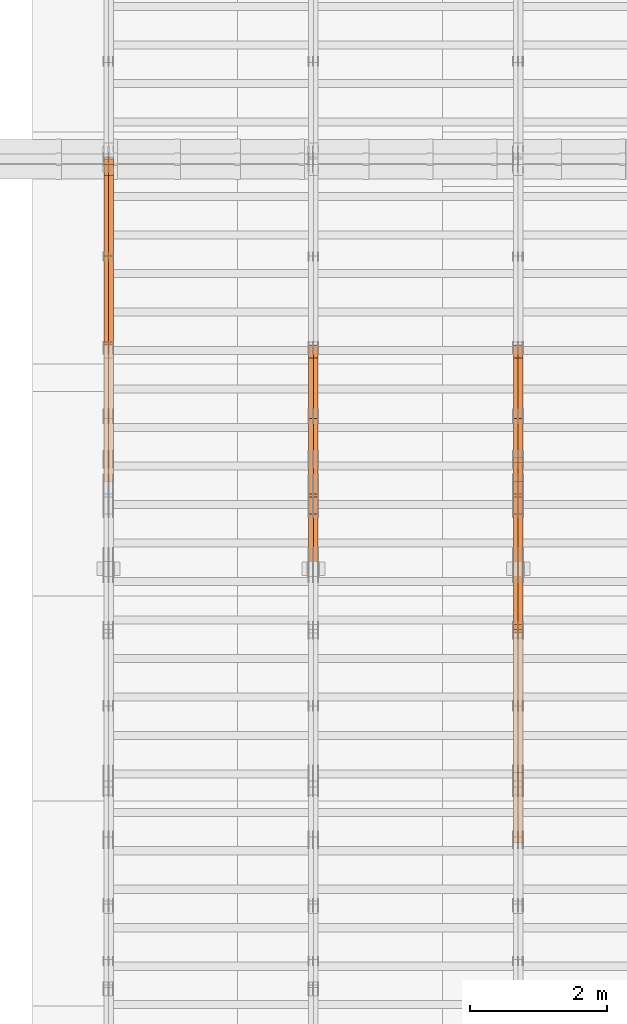
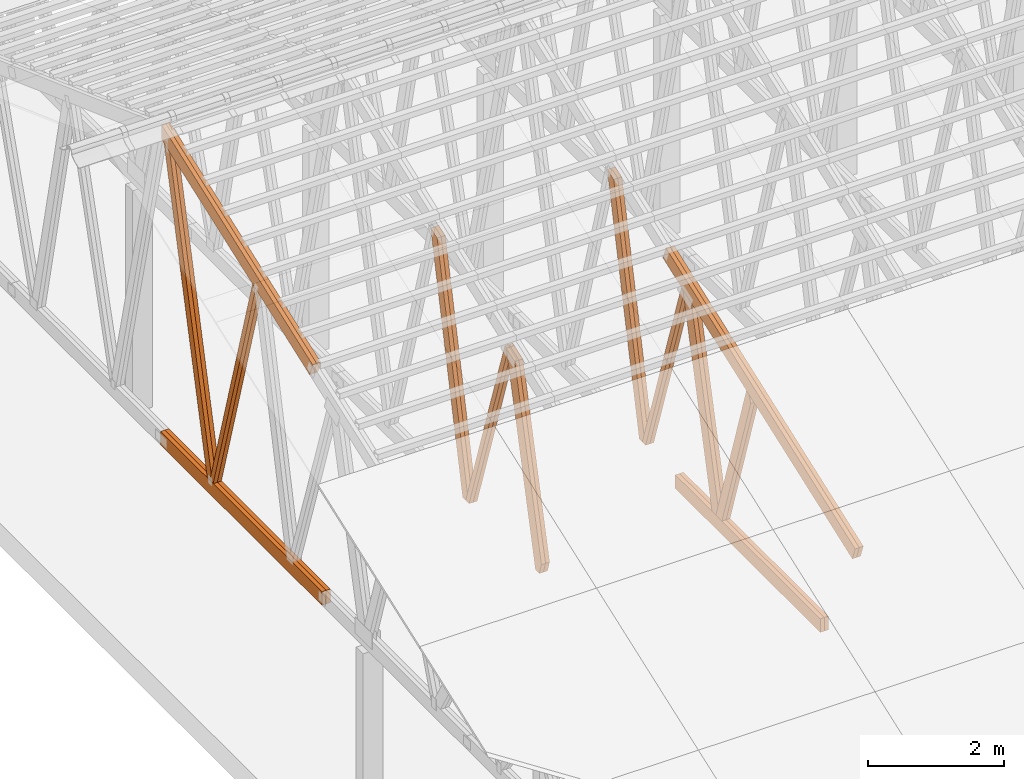
# One storey, part 16 of 189: 26 proxies.
"""IFC2X3 building model written with IfcOpenShell, lengths in millimetres."""

from ifc_helpers import new_model, entity, si_unit, converted_unit, derived_unit, direction, frame, origin, origin_2d_with_axis, place, context, subcontext, project, spatial, polyline, rectangle, outline, extrude, source, transform, mapped, material, type_object, type_shapes, element, save


model = new_model("IFC2X3")

# Units and contexts
model_context = context("Model", 3, precision=0.01, world=origin(), true_north=direction((6.12303176911189e-17, 1.0)))
body_context = subcontext(model_context, "Body", "Model", "MODEL_VIEW")
ifc_project = project(units=[si_unit("LENGTHUNIT", "METRE", prefix="MILLI"), si_unit("AREAUNIT", "SQUARE_METRE"), si_unit("VOLUMEUNIT", "CUBIC_METRE"), converted_unit("PLANEANGLEUNIT", "DEGREE", entity("IfcRatioMeasure", 0.0174532925199433), si_unit("PLANEANGLEUNIT", "RADIAN"), dimensions=[0, 0, 0, 0, 0, 0, 0]), si_unit("MASSUNIT", "GRAM", prefix="KILO"), derived_unit("MASSDENSITYUNIT", [(si_unit("MASSUNIT", "GRAM", prefix="KILO"), 1), (si_unit("LENGTHUNIT", "METRE"), -3)]), si_unit("TIMEUNIT", "SECOND"), si_unit("FREQUENCYUNIT", "HERTZ"), si_unit("THERMODYNAMICTEMPERATUREUNIT", "DEGREE_CELSIUS"), derived_unit("THERMALTRANSMITTANCEUNIT", [(si_unit("MASSUNIT", "GRAM", prefix="KILO"), 1), (si_unit("THERMODYNAMICTEMPERATUREUNIT", "KELVIN"), -1), (si_unit("TIMEUNIT", "SECOND"), -3)]), derived_unit("VOLUMETRICFLOWRATEUNIT", [(si_unit("LENGTHUNIT", "METRE"), 3), (si_unit("TIMEUNIT", "SECOND"), -1)]), si_unit("ELECTRICCURRENTUNIT", "AMPERE"), si_unit("ELECTRICVOLTAGEUNIT", "VOLT"), si_unit("POWERUNIT", "WATT"), si_unit("FORCEUNIT", "NEWTON"), si_unit("ILLUMINANCEUNIT", "LUX"), si_unit("LUMINOUSFLUXUNIT", "LUMEN"), si_unit("LUMINOUSINTENSITYUNIT", "CANDELA"), derived_unit("USERDEFINED", [(si_unit("MASSUNIT", "GRAM", prefix="KILO"), -1), (si_unit("LENGTHUNIT", "METRE"), -2), (si_unit("TIMEUNIT", "SECOND"), 3), (si_unit("LUMINOUSFLUXUNIT", "LUMEN"), 1)]), derived_unit("LINEARVELOCITYUNIT", [(si_unit("LENGTHUNIT", "METRE"), 1), (si_unit("TIMEUNIT", "SECOND"), -1)]), si_unit("PRESSUREUNIT", "PASCAL"), derived_unit("USERDEFINED", [(si_unit("LENGTHUNIT", "METRE"), -2), (si_unit("MASSUNIT", "GRAM", prefix="KILO"), 1), (si_unit("TIMEUNIT", "SECOND"), -2)])], contexts=[model_context])

# Site, building, storey
site_placement = place(None, origin())
site = spatial("IfcSite", under=ifc_project, at=site_placement, CompositionType="ELEMENT")
building_placement = place(site_placement, origin())
building = spatial("IfcBuilding", under=site, at=building_placement, CompositionType="ELEMENT")
storey_placement = place(building_placement, origin())
storey = spatial("IfcBuildingStorey", under=building, at=storey_placement, Name="Default", CompositionType="ELEMENT", Elevation=0.0)

# Proxies
ifc_material_1 = material(Name="IfcSurfaceStyle #36526")
building_element_proxy_type_1 = type_object("IfcBuildingElementProxyType", Name="T1-W3 36524", PredefinedType="NOTDEFINED", material=ifc_material_1)
shared_shape_1 = source(origin(), body_context, "Body", "SweptSolid", [
    extrude(outline(polyline([(-2625.55080717397, -84.9998286237256), (1749.48871563991, -84.9998286237256), (1768.20584427244, 0.000602085469291858), (1625.445846867, 85.0000405971208), (-2517.58959960538, 84.9990145648612), (-2625.55080717397, -84.9998286237256)])), frame((1768.20584427244, 85.0000405971208, 0.0), z_axis=(0.0, 0.0, 1.0), x_axis=(-1.0, 0.0, 0.0)), (0.0, 0.0, 1.0), 69.9999999999997),
])
type_shapes(building_element_proxy_type_1, [shared_shape_1])
proxy_1_placement = place(building_placement, frame((6335.0, 10918.6728403286, 263.278932236374), z_axis=(-1.0, 0.0, 0.0), x_axis=(0.0, 0.215047682154604, 0.976603550269982)))
element("IfcBuildingElementProxy", 1, at=proxy_1_placement, inside=storey, type_object=building_element_proxy_type_1, material=ifc_material_1, Name="T1-W3", context=body_context, shape_type="MappedRepresentation", body=[
    mapped(shared_shape_1, transform((0.0, 0.0, 0.0), scale=1.0)),
])
ifc_material_2 = material(Name="IfcSurfaceStyle #36460")
building_element_proxy_type_2 = type_object("IfcBuildingElementProxyType", Name="T1-W3 36458", PredefinedType="NOTDEFINED", material=ifc_material_2)
shared_shape_2 = source(origin(), body_context, "Body", "SweptSolid", [
    extrude(outline(polyline([(-2625.55080717397, -84.9998286237256), (1749.48871563991, -84.9998286237256), (1768.20584427244, 0.000602085469291858), (1625.445846867, 85.0000405971208), (-2517.58959960538, 84.9990145648612), (-2625.55080717397, -84.9998286237256)])), frame((1768.20584427244, 85.0000405971208, 0.0), z_axis=(0.0, 0.0, 1.0), x_axis=(-1.0, 0.0, 0.0)), (0.0, 0.0, 1.0), 69.9999999999997),
])
type_shapes(building_element_proxy_type_2, [shared_shape_2])
proxy_2_placement = place(building_placement, frame((6265.0, 10918.6728403286, 263.278932236374), z_axis=(-1.0, 0.0, 0.0), x_axis=(0.0, 0.215047682154604, 0.976603550269982)))
element("IfcBuildingElementProxy", 2, at=proxy_2_placement, inside=storey, type_object=building_element_proxy_type_2, material=ifc_material_2, Name="T1-W3", context=body_context, shape_type="MappedRepresentation", body=[
    mapped(shared_shape_2, transform((0.0, 0.0, 0.0), scale=1.0)),
])
ifc_material_3 = material(Name="IfcSurfaceStyle #36262")
building_element_proxy_type_3 = type_object("IfcBuildingElementProxyType", Name="T1-W7 36260", PredefinedType="NOTDEFINED", material=ifc_material_3)
shared_shape_3 = source(origin(), body_context, "Body", "SweptSolid", [
    extrude(outline(polyline([(-2158.15323194511, -47.5001976605119), (1398.58481981178, -47.5001976605119), (1473.93376219819, -0.000131511554346808), (1475.30069254941, 47.5002634162891), (-2189.66604261427, 47.5002634162891), (-2158.15323194511, -47.5001976605119)])), frame((1475.30069254941, 47.5002634162891, 0.0), z_axis=(0.0, 0.0, 1.0), x_axis=(-1.0, 0.0, 0.0)), (0.0, 0.0, 1.0), 69.9999999999998),
])
type_shapes(building_element_proxy_type_3, [shared_shape_3])
proxy_3_placement = place(building_placement, frame((6335.0, 9847.787109375, 3723.57788085937), z_axis=(-1.0, 0.0, 0.0), x_axis=(0.0, 0.314845237923105, -0.949143021971475)))
element("IfcBuildingElementProxy", 3, at=proxy_3_placement, inside=storey, type_object=building_element_proxy_type_3, material=ifc_material_3, Name="T1-W7", context=body_context, shape_type="MappedRepresentation", body=[
    mapped(shared_shape_3, transform((0.0, 0.0, 0.0), scale=1.0)),
])
ifc_material_4 = material(Name="IfcSurfaceStyle #36196")
building_element_proxy_type_4 = type_object("IfcBuildingElementProxyType", Name="T1-W7 36194", PredefinedType="NOTDEFINED", material=ifc_material_4)
shared_shape_4 = source(origin(), body_context, "Body", "SweptSolid", [
    extrude(outline(polyline([(-2158.15323194511, -47.5001976605119), (1398.58481981178, -47.5001976605119), (1473.93376219819, -0.000131511554346808), (1475.30069254941, 47.5002634162891), (-2189.66604261427, 47.5002634162891), (-2158.15323194511, -47.5001976605119)])), frame((1475.30069254941, 47.5002634162891, 0.0), z_axis=(0.0, 0.0, 1.0), x_axis=(-1.0, 0.0, 0.0)), (0.0, 0.0, 1.0), 69.9999999999998),
])
type_shapes(building_element_proxy_type_4, [shared_shape_4])
proxy_4_placement = place(building_placement, frame((6265.0, 9847.787109375, 3723.57788085937), z_axis=(-1.0, 0.0, 0.0), x_axis=(0.0, 0.314845237923105, -0.949143021971475)))
element("IfcBuildingElementProxy", 4, at=proxy_4_placement, inside=storey, type_object=building_element_proxy_type_4, material=ifc_material_4, Name="T1-W7", context=body_context, shape_type="MappedRepresentation", body=[
    mapped(shared_shape_4, transform((0.0, 0.0, 0.0), scale=1.0)),
])
ifc_material_5 = material(Name="IfcSurfaceStyle #35998")
building_element_proxy_type_5 = type_object("IfcBuildingElementProxyType", Name="T1-W1 35996", PredefinedType="NOTDEFINED", material=ifc_material_5)
shared_shape_5 = source(origin(), body_context, "Body", "SweptSolid", [
    extrude(outline(polyline([(-2144.69382208629, -109.99948311278), (1421.70798092021, -109.99948311278), (1448.88116133745, -0.000392715405943322), (1271.09900468242, 109.999679470483), (-1996.99432485378, 109.999679470483), (-2144.69382208629, -109.99948311278)])), frame((1448.88130194731, 110.000176487146, 0.0), z_axis=(0.0, 0.0, 1.0), x_axis=(-1.0, 0.0, 0.0)), (0.0, 0.0, 1.0), 69.9999999999998),
])
type_shapes(building_element_proxy_type_5, [shared_shape_5])
proxy_5_placement = place(building_placement, frame((6335.0, 8727.74270166583, 271.380182391418), z_axis=(-1.0, 0.0, 0.0), x_axis=(0.0, 0.239819839925978, 0.970817410421691)))
element("IfcBuildingElementProxy", 5, at=proxy_5_placement, inside=storey, type_object=building_element_proxy_type_5, material=ifc_material_5, Name="T1-W1", context=body_context, shape_type="MappedRepresentation", body=[
    mapped(shared_shape_5, transform((0.0, 0.0, 0.0), scale=1.0)),
])
ifc_material_6 = material(Name="IfcSurfaceStyle #35932")
building_element_proxy_type_6 = type_object("IfcBuildingElementProxyType", Name="T1-W1 35930", PredefinedType="NOTDEFINED", material=ifc_material_6)
shared_shape_6 = source(origin(), body_context, "Body", "SweptSolid", [
    extrude(outline(polyline([(-2144.69382208629, -109.99948311278), (1421.70798092021, -109.99948311278), (1448.88116133745, -0.000392715405943322), (1271.09900468242, 109.999679470483), (-1996.99432485378, 109.999679470483), (-2144.69382208629, -109.99948311278)])), frame((1448.88130194731, 110.000176487146, 0.0), z_axis=(0.0, 0.0, 1.0), x_axis=(-1.0, 0.0, 0.0)), (0.0, 0.0, 1.0), 69.9999999999998),
])
type_shapes(building_element_proxy_type_6, [shared_shape_6])
proxy_6_placement = place(building_placement, frame((6265.0, 8727.74270166583, 271.380182391418), z_axis=(-1.0, 0.0, 0.0), x_axis=(0.0, 0.239819839925978, 0.970817410421691)))
element("IfcBuildingElementProxy", 6, at=proxy_6_placement, inside=storey, type_object=building_element_proxy_type_6, material=ifc_material_6, Name="T1-W1", context=body_context, shape_type="MappedRepresentation", body=[
    mapped(shared_shape_6, transform((0.0, 0.0, 0.0), scale=1.0)),
])
ifc_material_7 = material(Name="IfcSurfaceStyle #35734")
building_element_proxy_type_7 = type_object("IfcBuildingElementProxyType", Name="T1-W4 35732", PredefinedType="NOTDEFINED", material=ifc_material_7)
shared_shape_7 = source(origin(), body_context, "Body", "SweptSolid", [
    extrude(outline(polyline([(-1688.09292256655, -85.0003489723785), (1071.44998120742, -85.0003489723785), (1178.19407811536, -0.00016040063201781), (1181.35435681367, 85.0004291726946), (-1742.9054935699, 85.0004291726946), (-1688.09292256655, -85.0003489723785)])), frame((1181.35446122976, 85.0007670757732, 0.0), z_axis=(0.0, 0.0, 1.0), x_axis=(-1.0, 0.0, 0.0)), (0.0, 0.0, 1.0), 69.9999999999998),
])
type_shapes(building_element_proxy_type_7, [shared_shape_7])
proxy_7_placement = place(building_placement, frame((6335.0, 7937.17021143291, 3028.170124945), z_axis=(-1.0, 0.0, 0.0), x_axis=(0.0, 0.306868406216492, -0.951751953644514)))
element("IfcBuildingElementProxy", 7, at=proxy_7_placement, inside=storey, type_object=building_element_proxy_type_7, material=ifc_material_7, Name="T1-W4", context=body_context, shape_type="MappedRepresentation", body=[
    mapped(shared_shape_7, transform((0.0, 0.0, 0.0), scale=1.0)),
])
ifc_material_8 = material(Name="IfcSurfaceStyle #35668")
building_element_proxy_type_8 = type_object("IfcBuildingElementProxyType", Name="T1-W4 35666", PredefinedType="NOTDEFINED", material=ifc_material_8)
shared_shape_8 = source(origin(), body_context, "Body", "SweptSolid", [
    extrude(outline(polyline([(-1688.09292256655, -85.0003489723785), (1071.44998120742, -85.0003489723785), (1178.19407811536, -0.00016040063201781), (1181.35435681367, 85.0004291726946), (-1742.9054935699, 85.0004291726946), (-1688.09292256655, -85.0003489723785)])), frame((1181.35446122976, 85.0007670757732, 0.0), z_axis=(0.0, 0.0, 1.0), x_axis=(-1.0, 0.0, 0.0)), (0.0, 0.0, 1.0), 69.9999999999998),
])
type_shapes(building_element_proxy_type_8, [shared_shape_8])
proxy_8_placement = place(building_placement, frame((6265.0, 7937.17021143291, 3028.170124945), z_axis=(-1.0, 0.0, 0.0), x_axis=(0.0, 0.306868406216492, -0.951751953644514)))
element("IfcBuildingElementProxy", 8, at=proxy_8_placement, inside=storey, type_object=building_element_proxy_type_8, material=ifc_material_8, Name="T1-W4", context=body_context, shape_type="MappedRepresentation", body=[
    mapped(shared_shape_8, transform((0.0, 0.0, 0.0), scale=1.0)),
])
ifc_material_9 = material(Name="IfcSurfaceStyle #32656")
building_element_proxy_type_9 = type_object("IfcBuildingElementProxyType", Name="T1-B6 32654", PredefinedType="NOTDEFINED", material=ifc_material_9)
shared_shape_9 = source(origin(), body_context, "Body", "SweptSolid", [
    extrude(rectangle(XDim=4266.763671875, YDim=245.000000000001, at=origin_2d_with_axis()), frame((2133.3818359375, 122.500000000001, 0.0), z_axis=(0.0, 0.0, 1.0), x_axis=(-1.0, 0.0, 0.0)), (0.0, 0.0, 1.0), 69.9999999999997),
])
type_shapes(building_element_proxy_type_9, [shared_shape_9])
proxy_9_placement = place(building_placement, frame((6335.0, 5762.466796875, 245.0), z_axis=(-1.0, 0.0, 0.0), x_axis=(0.0, 1.0, 0.0)))
element("IfcBuildingElementProxy", 9, at=proxy_9_placement, inside=storey, type_object=building_element_proxy_type_9, material=ifc_material_9, Name="T1-B6", context=body_context, shape_type="MappedRepresentation", body=[
    mapped(shared_shape_9, transform((0.0, 0.0, 0.0), scale=1.0)),
])
ifc_material_10 = material(Name="IfcSurfaceStyle #32599")
building_element_proxy_type_10 = type_object("IfcBuildingElementProxyType", Name="T1-B6 32597", PredefinedType="NOTDEFINED", material=ifc_material_10)
shared_shape_10 = source(origin(), body_context, "Body", "SweptSolid", [
    extrude(rectangle(XDim=4266.763671875, YDim=245.000000000001, at=origin_2d_with_axis()), frame((2133.3818359375, 122.500000000001, 0.0), z_axis=(0.0, 0.0, 1.0), x_axis=(-1.0, 0.0, 0.0)), (0.0, 0.0, 1.0), 69.9999999999997),
])
type_shapes(building_element_proxy_type_10, [shared_shape_10])
proxy_10_placement = place(building_placement, frame((6265.0, 5762.466796875, 245.0), z_axis=(-1.0, 0.0, 0.0), x_axis=(0.0, 1.0, 0.0)))
element("IfcBuildingElementProxy", 10, at=proxy_10_placement, inside=storey, type_object=building_element_proxy_type_10, material=ifc_material_10, Name="T1-B6", context=body_context, shape_type="MappedRepresentation", body=[
    mapped(shared_shape_10, transform((0.0, 0.0, 0.0), scale=1.0)),
])
ifc_material_11 = material(Name="IfcSurfaceStyle #32296")
building_element_proxy_type_11 = type_object("IfcBuildingElementProxyType", Name="T1-T1 32294", PredefinedType="NOTDEFINED", material=ifc_material_11)
shared_shape_11 = source(origin(), body_context, "Body", "SweptSolid", [
    extrude(outline(polyline([(-2964.99981923522, -122.500027388895), (2964.99982426074, -122.500027388895), (2964.99984011048, 122.500027388895), (-2964.99984513599, 122.500027388895), (-2964.99981923522, -122.500027388895)])), frame((2965.00021857317, 122.500056320695, 0.0), z_axis=(0.0, 0.0, 1.0), x_axis=(-1.0, 0.0, 0.0)), (0.0, 0.0, 1.0), 69.9999999999996),
])
type_shapes(building_element_proxy_type_11, [shared_shape_11])
proxy_11_placement = place(building_placement, frame((6335.0, 10391.0374749089, 3921.30478975487), z_axis=(-1.0, 0.0, 0.0), x_axis=(0.0, -0.939692620785908, -0.342020143325669)))
element("IfcBuildingElementProxy", 11, at=proxy_11_placement, inside=storey, type_object=building_element_proxy_type_11, material=ifc_material_11, Name="T1-T1", context=body_context, shape_type="MappedRepresentation", body=[
    mapped(shared_shape_11, transform((0.0, 0.0, 0.0), scale=1.0)),
])
ifc_material_12 = material(Name="IfcSurfaceStyle #32239")
building_element_proxy_type_12 = type_object("IfcBuildingElementProxyType", Name="T1-T1 32237", PredefinedType="NOTDEFINED", material=ifc_material_12)
shared_shape_12 = source(origin(), body_context, "Body", "SweptSolid", [
    extrude(outline(polyline([(-2964.99981923522, -122.500027388895), (2964.99982426074, -122.500027388895), (2964.99984011048, 122.500027388895), (-2964.99984513599, 122.500027388895), (-2964.99981923522, -122.500027388895)])), frame((2965.00021857317, 122.500056320695, 0.0), z_axis=(0.0, 0.0, 1.0), x_axis=(-1.0, 0.0, 0.0)), (0.0, 0.0, 1.0), 69.9999999999996),
])
type_shapes(building_element_proxy_type_12, [shared_shape_12])
proxy_12_placement = place(building_placement, frame((6265.0, 10391.0374749089, 3921.30478975487), z_axis=(-1.0, 0.0, 0.0), x_axis=(0.0, -0.939692620785908, -0.342020143325669)))
element("IfcBuildingElementProxy", 12, at=proxy_12_placement, inside=storey, type_object=building_element_proxy_type_12, material=ifc_material_12, Name="T1-T1", context=body_context, shape_type="MappedRepresentation", body=[
    mapped(shared_shape_12, transform((0.0, 0.0, 0.0), scale=1.0)),
])
ifc_material_13 = material(Name="IfcSurfaceStyle #20736")
building_element_proxy_type_13 = type_object("IfcBuildingElementProxyType", Name="T1-W3 20734", PredefinedType="NOTDEFINED", material=ifc_material_13)
shared_shape_13 = source(origin(), body_context, "Body", "SweptSolid", [
    extrude(outline(polyline([(-2625.55080717397, -84.9998286237256), (1749.48871563991, -84.9998286237256), (1768.20584427244, 0.000602085469291858), (1625.445846867, 85.0000405971208), (-2517.58959960538, 84.9990145648612), (-2625.55080717397, -84.9998286237256)])), frame((1768.20584427244, 85.0000405971208, 0.0), z_axis=(0.0, 0.0, 1.0), x_axis=(-1.0, 0.0, 0.0)), (0.0, 0.0, 1.0), 69.9999999999997),
])
type_shapes(building_element_proxy_type_13, [shared_shape_13])
proxy_13_placement = place(building_placement, frame((3335.0, 10918.6728403286, 263.278932236374), z_axis=(-1.0, 0.0, 0.0), x_axis=(0.0, 0.215047682154604, 0.976603550269982)))
element("IfcBuildingElementProxy", 13, at=proxy_13_placement, inside=storey, type_object=building_element_proxy_type_13, material=ifc_material_13, Name="T1-W3", context=body_context, shape_type="MappedRepresentation", body=[
    mapped(shared_shape_13, transform((0.0, 0.0, 0.0), scale=1.0)),
])
ifc_material_14 = material(Name="IfcSurfaceStyle #20670")
building_element_proxy_type_14 = type_object("IfcBuildingElementProxyType", Name="T1-W3 20668", PredefinedType="NOTDEFINED", material=ifc_material_14)
shared_shape_14 = source(origin(), body_context, "Body", "SweptSolid", [
    extrude(outline(polyline([(-2625.55080717397, -84.9998286237256), (1749.48871563991, -84.9998286237256), (1768.20584427244, 0.000602085469291858), (1625.445846867, 85.0000405971208), (-2517.58959960538, 84.9990145648612), (-2625.55080717397, -84.9998286237256)])), frame((1768.20584427244, 85.0000405971208, 0.0), z_axis=(0.0, 0.0, 1.0), x_axis=(-1.0, 0.0, 0.0)), (0.0, 0.0, 1.0), 69.9999999999997),
])
type_shapes(building_element_proxy_type_14, [shared_shape_14])
proxy_14_placement = place(building_placement, frame((3265.0, 10918.6728403286, 263.278932236374), z_axis=(-1.0, 0.0, 0.0), x_axis=(0.0, 0.215047682154604, 0.976603550269982)))
element("IfcBuildingElementProxy", 14, at=proxy_14_placement, inside=storey, type_object=building_element_proxy_type_14, material=ifc_material_14, Name="T1-W3", context=body_context, shape_type="MappedRepresentation", body=[
    mapped(shared_shape_14, transform((0.0, 0.0, 0.0), scale=1.0)),
])
ifc_material_15 = material(Name="IfcSurfaceStyle #20472")
building_element_proxy_type_15 = type_object("IfcBuildingElementProxyType", Name="T1-W7 20470", PredefinedType="NOTDEFINED", material=ifc_material_15)
shared_shape_15 = source(origin(), body_context, "Body", "SweptSolid", [
    extrude(outline(polyline([(-2158.15323194511, -47.5001976605119), (1398.58481981178, -47.5001976605119), (1473.93376219819, -0.000131511554346808), (1475.30069254941, 47.5002634162891), (-2189.66604261427, 47.5002634162891), (-2158.15323194511, -47.5001976605119)])), frame((1475.30069254941, 47.5002634162891, 0.0), z_axis=(0.0, 0.0, 1.0), x_axis=(-1.0, 0.0, 0.0)), (0.0, 0.0, 1.0), 69.9999999999998),
])
type_shapes(building_element_proxy_type_15, [shared_shape_15])
proxy_15_placement = place(building_placement, frame((3335.0, 9847.787109375, 3723.57788085937), z_axis=(-1.0, 0.0, 0.0), x_axis=(0.0, 0.314845237923105, -0.949143021971475)))
element("IfcBuildingElementProxy", 15, at=proxy_15_placement, inside=storey, type_object=building_element_proxy_type_15, material=ifc_material_15, Name="T1-W7", context=body_context, shape_type="MappedRepresentation", body=[
    mapped(shared_shape_15, transform((0.0, 0.0, 0.0), scale=1.0)),
])
ifc_material_16 = material(Name="IfcSurfaceStyle #20406")
building_element_proxy_type_16 = type_object("IfcBuildingElementProxyType", Name="T1-W7 20404", PredefinedType="NOTDEFINED", material=ifc_material_16)
shared_shape_16 = source(origin(), body_context, "Body", "SweptSolid", [
    extrude(outline(polyline([(-2158.15323194511, -47.5001976605119), (1398.58481981178, -47.5001976605119), (1473.93376219819, -0.000131511554346808), (1475.30069254941, 47.5002634162891), (-2189.66604261427, 47.5002634162891), (-2158.15323194511, -47.5001976605119)])), frame((1475.30069254941, 47.5002634162891, 0.0), z_axis=(0.0, 0.0, 1.0), x_axis=(-1.0, 0.0, 0.0)), (0.0, 0.0, 1.0), 69.9999999999998),
])
type_shapes(building_element_proxy_type_16, [shared_shape_16])
proxy_16_placement = place(building_placement, frame((3265.0, 9847.787109375, 3723.57788085937), z_axis=(-1.0, 0.0, 0.0), x_axis=(0.0, 0.314845237923105, -0.949143021971475)))
element("IfcBuildingElementProxy", 16, at=proxy_16_placement, inside=storey, type_object=building_element_proxy_type_16, material=ifc_material_16, Name="T1-W7", context=body_context, shape_type="MappedRepresentation", body=[
    mapped(shared_shape_16, transform((0.0, 0.0, 0.0), scale=1.0)),
])
ifc_material_17 = material(Name="IfcSurfaceStyle #20208")
building_element_proxy_type_17 = type_object("IfcBuildingElementProxyType", Name="T1-W1 20206", PredefinedType="NOTDEFINED", material=ifc_material_17)
shared_shape_17 = source(origin(), body_context, "Body", "SweptSolid", [
    extrude(outline(polyline([(-2144.69382208629, -109.99948311278), (1421.70798092021, -109.99948311278), (1448.88116133745, -0.000392715405943322), (1271.09900468242, 109.999679470483), (-1996.99432485378, 109.999679470483), (-2144.69382208629, -109.99948311278)])), frame((1448.88130194731, 110.000176487146, 0.0), z_axis=(0.0, 0.0, 1.0), x_axis=(-1.0, 0.0, 0.0)), (0.0, 0.0, 1.0), 69.9999999999998),
])
type_shapes(building_element_proxy_type_17, [shared_shape_17])
proxy_17_placement = place(building_placement, frame((3335.0, 8727.74270166583, 271.380182391418), z_axis=(-1.0, 0.0, 0.0), x_axis=(0.0, 0.239819839925978, 0.970817410421691)))
element("IfcBuildingElementProxy", 17, at=proxy_17_placement, inside=storey, type_object=building_element_proxy_type_17, material=ifc_material_17, Name="T1-W1", context=body_context, shape_type="MappedRepresentation", body=[
    mapped(shared_shape_17, transform((0.0, 0.0, 0.0), scale=1.0)),
])
ifc_material_18 = material(Name="IfcSurfaceStyle #20142")
building_element_proxy_type_18 = type_object("IfcBuildingElementProxyType", Name="T1-W1 20140", PredefinedType="NOTDEFINED", material=ifc_material_18)
shared_shape_18 = source(origin(), body_context, "Body", "SweptSolid", [
    extrude(outline(polyline([(-2144.69382208629, -109.99948311278), (1421.70798092021, -109.99948311278), (1448.88116133745, -0.000392715405943322), (1271.09900468242, 109.999679470483), (-1996.99432485378, 109.999679470483), (-2144.69382208629, -109.99948311278)])), frame((1448.88130194731, 110.000176487146, 0.0), z_axis=(0.0, 0.0, 1.0), x_axis=(-1.0, 0.0, 0.0)), (0.0, 0.0, 1.0), 69.9999999999998),
])
type_shapes(building_element_proxy_type_18, [shared_shape_18])
proxy_18_placement = place(building_placement, frame((3265.0, 8727.74270166583, 271.380182391418), z_axis=(-1.0, 0.0, 0.0), x_axis=(0.0, 0.239819839925978, 0.970817410421691)))
element("IfcBuildingElementProxy", 18, at=proxy_18_placement, inside=storey, type_object=building_element_proxy_type_18, material=ifc_material_18, Name="T1-W1", context=body_context, shape_type="MappedRepresentation", body=[
    mapped(shared_shape_18, transform((0.0, 0.0, 0.0), scale=1.0)),
])
ifc_material_19 = material(Name="IfcSurfaceStyle #5471")
building_element_proxy_type_19 = type_object("IfcBuildingElementProxyType", Name="T1-W5 5469", PredefinedType="NOTDEFINED", material=ifc_material_19)
shared_shape_19 = source(origin(), body_context, "Body", "SweptSolid", [
    extrude(outline(polyline([(-3233.61216530572, -72.4999091305202), (2153.79187521892, -72.4999091305202), (2171.36968478227, -7.18521572819375e-05), (2045.62106208646, 72.4999450565989), (-3137.17045678193, 72.4999450565989), (-3233.61216530572, -72.4999091305202)])), frame((2171.36968478227, 72.500192121173, 0.0), z_axis=(0.0, 0.0, 1.0), x_axis=(-1.0, 0.0, 0.0)), (0.0, 0.0, 1.0), 69.9999999999997),
])
type_shapes(building_element_proxy_type_19, [shared_shape_19])
proxy_19_placement = place(building_placement, frame((335.0, 13261.0146935344, 262.082919891325), z_axis=(-1.0, 0.0, 0.0), x_axis=(0.0, 0.235625623344066, 0.97184389982328)))
element("IfcBuildingElementProxy", 19, at=proxy_19_placement, inside=storey, type_object=building_element_proxy_type_19, material=ifc_material_19, Name="T1-W5", context=body_context, shape_type="MappedRepresentation", body=[
    mapped(shared_shape_19, transform((0.0, 0.0, 0.0), scale=1.0)),
])
ifc_material_20 = material(Name="IfcSurfaceStyle #5405")
building_element_proxy_type_20 = type_object("IfcBuildingElementProxyType", Name="T1-W5 5403", PredefinedType="NOTDEFINED", material=ifc_material_20)
shared_shape_20 = source(origin(), body_context, "Body", "SweptSolid", [
    extrude(outline(polyline([(-3233.61216530572, -72.4999091305202), (2153.79187521892, -72.4999091305202), (2171.36968478227, -7.18521572819375e-05), (2045.62106208646, 72.4999450565989), (-3137.17045678193, 72.4999450565989), (-3233.61216530572, -72.4999091305202)])), frame((2171.36968478227, 72.500192121173, 0.0), z_axis=(0.0, 0.0, 1.0), x_axis=(-1.0, 0.0, 0.0)), (0.0, 0.0, 1.0), 69.9999999999997),
])
type_shapes(building_element_proxy_type_20, [shared_shape_20])
proxy_20_placement = place(building_placement, frame((265.0, 13261.0146935344, 262.082919891325), z_axis=(-1.0, 0.0, 0.0), x_axis=(0.0, 0.235625623344066, 0.97184389982328)))
element("IfcBuildingElementProxy", 20, at=proxy_20_placement, inside=storey, type_object=building_element_proxy_type_20, material=ifc_material_20, Name="T1-W5", context=body_context, shape_type="MappedRepresentation", body=[
    mapped(shared_shape_20, transform((0.0, 0.0, 0.0), scale=1.0)),
])
ifc_material_21 = material(Name="IfcSurfaceStyle #5207")
building_element_proxy_type_21 = type_object("IfcBuildingElementProxyType", Name="T1-W6 5205", PredefinedType="NOTDEFINED", material=ifc_material_21)
shared_shape_21 = source(origin(), body_context, "Body", "SweptSolid", [
    extrude(outline(polyline([(-2640.84340836012, -47.4996765865792), (1711.12245024294, -47.4996765865792), (1797.68490303083, -9.57690019346202e-05), (1800.72595169379, 47.4997244710801), (-2668.68989660745, 47.4997244710801), (-2640.84340836012, -47.4996765865792)])), frame((1800.72595169379, 47.5003009358159, 0.0), z_axis=(0.0, 0.0, 1.0), x_axis=(-1.0, 0.0, 0.0)), (0.0, 0.0, 1.0), 69.9999999999997),
])
type_shapes(building_element_proxy_type_21, [shared_shape_21])
proxy_21_placement = place(building_placement, frame((335.0, 12074.2896156894, 4533.9586582452), z_axis=(-1.0, 0.0, 0.0), x_axis=(0.0, 0.28128598310461, -0.959623986626467)))
element("IfcBuildingElementProxy", 21, at=proxy_21_placement, inside=storey, type_object=building_element_proxy_type_21, material=ifc_material_21, Name="T1-W6", context=body_context, shape_type="MappedRepresentation", body=[
    mapped(shared_shape_21, transform((0.0, 0.0, 0.0), scale=1.0)),
])
ifc_material_22 = material(Name="IfcSurfaceStyle #5141")
building_element_proxy_type_22 = type_object("IfcBuildingElementProxyType", Name="T1-W6 5139", PredefinedType="NOTDEFINED", material=ifc_material_22)
shared_shape_22 = source(origin(), body_context, "Body", "SweptSolid", [
    extrude(outline(polyline([(-2640.84340836012, -47.4996765865792), (1711.12245024294, -47.4996765865792), (1797.68490303083, -9.57690019346202e-05), (1800.72595169379, 47.4997244710801), (-2668.68989660745, 47.4997244710801), (-2640.84340836012, -47.4996765865792)])), frame((1800.72595169379, 47.5003009358159, 0.0), z_axis=(0.0, 0.0, 1.0), x_axis=(-1.0, 0.0, 0.0)), (0.0, 0.0, 1.0), 69.9999999999997),
])
type_shapes(building_element_proxy_type_22, [shared_shape_22])
proxy_22_placement = place(building_placement, frame((265.0, 12074.2896156894, 4533.9586582452), z_axis=(-1.0, 0.0, 0.0), x_axis=(0.0, 0.28128598310461, -0.959623986626467)))
element("IfcBuildingElementProxy", 22, at=proxy_22_placement, inside=storey, type_object=building_element_proxy_type_22, material=ifc_material_22, Name="T1-W6", context=body_context, shape_type="MappedRepresentation", body=[
    mapped(shared_shape_22, transform((0.0, 0.0, 0.0), scale=1.0)),
])
ifc_material_23 = material(Name="IfcSurfaceStyle #1187")
building_element_proxy_type_23 = type_object("IfcBuildingElementProxyType", Name="T1-B3 1185", PredefinedType="NOTDEFINED", material=ifc_material_23)
shared_shape_23 = source(origin(), body_context, "Body", "SweptSolid", [
    extrude(rectangle(XDim=4751.0283203125, YDim=245.000000000001, at=origin_2d_with_axis()), frame((2375.51416015625, 122.5, 0.0), z_axis=(0.0, 0.0, 1.0), x_axis=(-1.0, 0.0, 0.0)), (0.0, 0.0, 1.0), 69.9999999999997),
])
type_shapes(building_element_proxy_type_23, [shared_shape_23])
proxy_23_placement = place(building_placement, frame((335.0, 10029.23046875, 245.0), z_axis=(-1.0, 0.0, 0.0), x_axis=(0.0, 1.0, 0.0)))
element("IfcBuildingElementProxy", 23, at=proxy_23_placement, inside=storey, type_object=building_element_proxy_type_23, material=ifc_material_23, Name="T1-B3", context=body_context, shape_type="MappedRepresentation", body=[
    mapped(shared_shape_23, transform((0.0, 0.0, 0.0), scale=1.0)),
])
ifc_material_24 = material(Name="IfcSurfaceStyle #1130")
building_element_proxy_type_24 = type_object("IfcBuildingElementProxyType", Name="T1-B3 1128", PredefinedType="NOTDEFINED", material=ifc_material_24)
shared_shape_24 = source(origin(), body_context, "Body", "SweptSolid", [
    extrude(rectangle(XDim=4751.0283203125, YDim=245.000000000001, at=origin_2d_with_axis()), frame((2375.51416015625, 122.5, 0.0), z_axis=(0.0, 0.0, 1.0), x_axis=(-1.0, 0.0, 0.0)), (0.0, 0.0, 1.0), 69.9999999999997),
])
type_shapes(building_element_proxy_type_24, [shared_shape_24])
proxy_24_placement = place(building_placement, frame((265.0, 10029.23046875, 245.0), z_axis=(-1.0, 0.0, 0.0), x_axis=(0.0, 1.0, 0.0)))
element("IfcBuildingElementProxy", 24, at=proxy_24_placement, inside=storey, type_object=building_element_proxy_type_24, material=ifc_material_24, Name="T1-B3", context=body_context, shape_type="MappedRepresentation", body=[
    mapped(shared_shape_24, transform((0.0, 0.0, 0.0), scale=1.0)),
])
ifc_material_25 = material(Name="IfcSurfaceStyle #599")
building_element_proxy_type_25 = type_object("IfcBuildingElementProxyType", Name="T1-T3 597", PredefinedType="NOTDEFINED", material=ifc_material_25)
shared_shape_25 = source(origin(), body_context, "Body", "SweptSolid", [
    extrude(outline(polyline([(-2341.64890001385, -122.499972785692), (2386.23525922045, -122.499972785692), (2297.06252495753, 122.499972785692), (-2341.64888416412, 122.499972785692), (-2341.64890001385, -122.499972785692)])), frame((2386.23525922045, 122.499973888764, 0.0), z_axis=(0.0, 0.0, 1.0), x_axis=(-1.0, 0.0, 0.0)), (0.0, 0.0, 1.0), 69.9999999999997),
])
type_shapes(building_element_proxy_type_25, [shared_shape_25])
proxy_25_placement = place(building_placement, frame((335.0, 14833.7949607394, 5538.33627266055), z_axis=(-1.0, 0.0, 0.0), x_axis=(0.0, -0.939692620785908, -0.342020143325669)))
element("IfcBuildingElementProxy", 25, at=proxy_25_placement, inside=storey, type_object=building_element_proxy_type_25, material=ifc_material_25, Name="T1-T3", context=body_context, shape_type="MappedRepresentation", body=[
    mapped(shared_shape_25, transform((0.0, 0.0, 0.0), scale=1.0)),
])
ifc_material_26 = material(Name="IfcSurfaceStyle #542")
building_element_proxy_type_26 = type_object("IfcBuildingElementProxyType", Name="T1-T3 540", PredefinedType="NOTDEFINED", material=ifc_material_26)
shared_shape_26 = source(origin(), body_context, "Body", "SweptSolid", [
    extrude(outline(polyline([(-2341.64890001385, -122.499972785692), (2386.23525922045, -122.499972785692), (2297.06252495753, 122.499972785692), (-2341.64888416412, 122.499972785692), (-2341.64890001385, -122.499972785692)])), frame((2386.23525922045, 122.499973888764, 0.0), z_axis=(0.0, 0.0, 1.0), x_axis=(-1.0, 0.0, 0.0)), (0.0, 0.0, 1.0), 69.9999999999997),
])
type_shapes(building_element_proxy_type_26, [shared_shape_26])
proxy_26_placement = place(building_placement, frame((265.0, 14833.7949607394, 5538.33627266055), z_axis=(-1.0, 0.0, 0.0), x_axis=(0.0, -0.939692620785908, -0.342020143325669)))
element("IfcBuildingElementProxy", 26, at=proxy_26_placement, inside=storey, type_object=building_element_proxy_type_26, material=ifc_material_26, Name="T1-T3", context=body_context, shape_type="MappedRepresentation", body=[
    mapped(shared_shape_26, transform((0.0, 0.0, 0.0), scale=1.0)),
])

save(model, "model.ifc")
